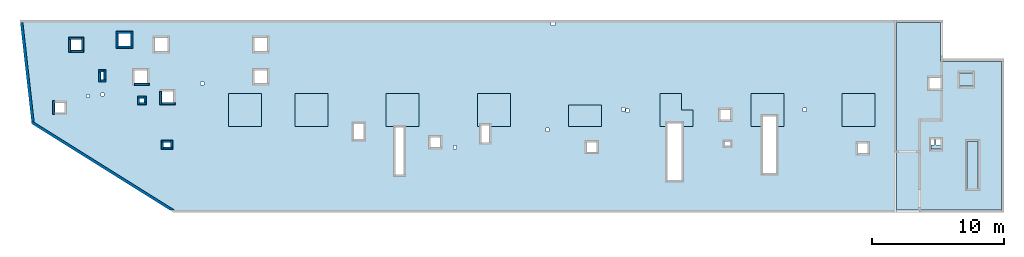
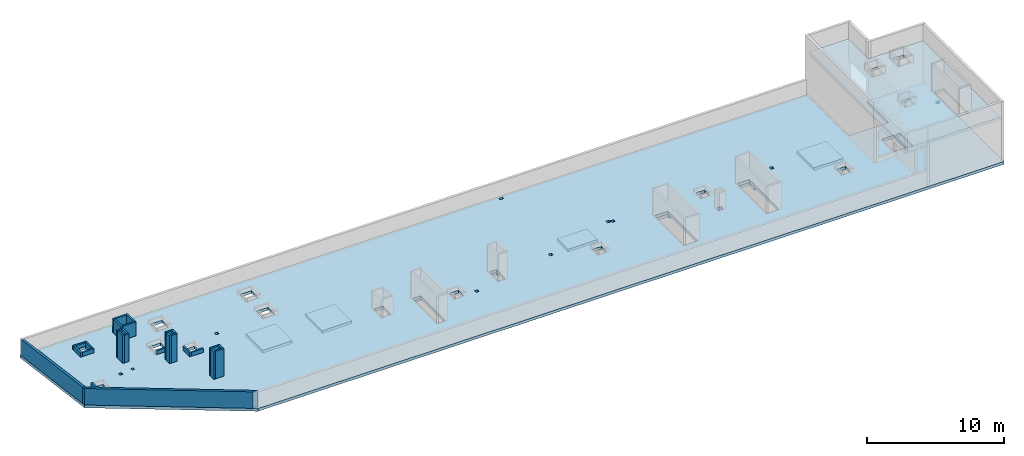
# One storey, part 1 of 3: 26 walls, 10 slabs.
"""IFC4 building model written with IfcOpenShell, lengths in millimetres."""

from ifc_helpers import new_model, entity, si_unit, converted_unit, derived_unit, direction, frame, origin, place, context, subcontext, project, spatial, indexed_curve, outline, extrude, material, type_object, element, save


model = new_model("IFC4")

# Units and contexts
model_context = context("Model", 3, precision=0.01, world=origin(), true_north=direction((6.12303176911189e-17, 1.0)))
plan_context = context("Plan", 3, precision=0.01, world=origin(), true_north=direction((6.12303176911189e-17, 1.0)))
body_context = subcontext(model_context, "Body", "Model", "MODEL_VIEW")
ifc_project = project(units=[si_unit("LENGTHUNIT", "METRE", prefix="MILLI"), si_unit("AREAUNIT", "SQUARE_METRE"), si_unit("VOLUMEUNIT", "CUBIC_METRE"), converted_unit("PLANEANGLEUNIT", "DEGREE", entity("IfcRatioMeasure", 0.0174532925199433), si_unit("PLANEANGLEUNIT", "RADIAN"), dimensions=[0, 0, 0, 0, 0, 0, 0]), si_unit("MASSUNIT", "GRAM", prefix="KILO"), derived_unit("MASSDENSITYUNIT", [(si_unit("MASSUNIT", "GRAM", prefix="KILO"), 1), (si_unit("LENGTHUNIT", "METRE"), -3)]), derived_unit("MOMENTOFINERTIAUNIT", [(si_unit("LENGTHUNIT", "METRE"), 4)]), si_unit("TIMEUNIT", "SECOND"), si_unit("FREQUENCYUNIT", "HERTZ"), si_unit("THERMODYNAMICTEMPERATUREUNIT", "DEGREE_CELSIUS"), derived_unit("THERMALTRANSMITTANCEUNIT", [(si_unit("MASSUNIT", "GRAM", prefix="KILO"), 1), (si_unit("THERMODYNAMICTEMPERATUREUNIT", "KELVIN"), -1), (si_unit("TIMEUNIT", "SECOND"), -3)]), derived_unit("VOLUMETRICFLOWRATEUNIT", [(si_unit("LENGTHUNIT", "METRE"), 3), (si_unit("TIMEUNIT", "SECOND"), -1)]), derived_unit("MASSFLOWRATEUNIT", [(si_unit("MASSUNIT", "GRAM", prefix="KILO"), 1), (si_unit("TIMEUNIT", "SECOND"), -1)]), derived_unit("ROTATIONALFREQUENCYUNIT", [(si_unit("TIMEUNIT", "SECOND"), -1)]), si_unit("ELECTRICCURRENTUNIT", "AMPERE"), si_unit("ELECTRICVOLTAGEUNIT", "VOLT"), si_unit("POWERUNIT", "WATT"), si_unit("FORCEUNIT", "NEWTON", prefix="KILO"), si_unit("ILLUMINANCEUNIT", "LUX"), si_unit("LUMINOUSFLUXUNIT", "LUMEN"), si_unit("LUMINOUSINTENSITYUNIT", "CANDELA"), derived_unit("USERDEFINED", [(si_unit("MASSUNIT", "GRAM", prefix="KILO"), -1), (si_unit("LENGTHUNIT", "METRE"), -2), (si_unit("TIMEUNIT", "SECOND"), 3), (si_unit("LUMINOUSFLUXUNIT", "LUMEN"), 1)]), derived_unit("LINEARVELOCITYUNIT", [(si_unit("LENGTHUNIT", "METRE"), 1), (si_unit("TIMEUNIT", "SECOND"), -1)]), si_unit("PRESSUREUNIT", "PASCAL"), derived_unit("USERDEFINED", [(si_unit("LENGTHUNIT", "METRE"), -2), (si_unit("MASSUNIT", "GRAM", prefix="KILO"), 1), (si_unit("TIMEUNIT", "SECOND"), -2)]), derived_unit("LINEARFORCEUNIT", [(si_unit("MASSUNIT", "GRAM", prefix="KILO"), 1), (si_unit("LENGTHUNIT", "METRE"), 1), (si_unit("TIMEUNIT", "SECOND"), -2), (si_unit("LENGTHUNIT", "METRE"), -1)]), derived_unit("PLANARFORCEUNIT", [(si_unit("MASSUNIT", "GRAM", prefix="KILO"), 1), (si_unit("LENGTHUNIT", "METRE"), 1), (si_unit("TIMEUNIT", "SECOND"), -2), (si_unit("LENGTHUNIT", "METRE"), -2)])], contexts=[model_context, plan_context])

# Site, building, storey
site_placement = place(None, origin())
site = spatial("IfcSite", under=ifc_project, at=site_placement, CompositionType="ELEMENT")
building_placement = place(site_placement, origin())
building = spatial("IfcBuilding", under=site, at=building_placement, CompositionType="ELEMENT")
storey_placement = place(building_placement, frame((0.0, 0.0, 32250.0)))
storey = spatial("IfcBuildingStorey", under=building, at=storey_placement, CompositionType="ELEMENT", Elevation=32250.0)

# Slabs
ifc_material = material()
slab_type_1 = type_object("IfcSlabType", PredefinedType="FLOOR", material=ifc_material)
slab_1_placement = place(storey_placement, origin())
element("IfcSlab", 1, at=slab_1_placement, inside=storey, type_object=slab_type_1, material=ifc_material, PredefinedType="FLOOR", context=body_context, shape_type="SweptSolid", body=[
    extrude(outline(indexed_curve([(-28210.243401448, -11264.7051743326), (34622.2927188456, -11264.7051743326), (34622.2927188456, 375.294825667434), (29822.2935367167, 375.294825667426), (29822.2935367167, -2764.70517433255), (26482.2935367167, -2764.70517433256), (26482.2935367167, 3305.29546503463), (-39839.7064632833, 3305.29546503461), (-38947.8468191642, -4555.23683038923), (-28210.243401448, -11264.7051743326)], self_intersect=False), holes=[indexed_curve([(-36462.7064632833, -2944.70517433183), (-36462.7064632833, -3694.70517433183), (-37212.7064632833, -3694.70517433183), (-37212.7064632833, -2944.70517433183), (-36462.7064632833, -2944.70517433183)], self_intersect=False), indexed_curve([(-35152.7064632833, 1855.29482566817), (-35152.7064632833, 1005.29482566817), (-36002.7064632834, 1005.29482566817), (-36002.7064632834, 1855.29482566817), (-35152.7064632833, 1855.29482566817)], self_intersect=False), indexed_curve([(-33497.7064632833, -2234.70517433184), (-33497.7064632833, -2434.70517433184), (-33697.7064632833, -2434.70517433184), (-33697.7064632833, -2234.70517433184), (-33497.7064632833, -2234.70517433184)], self_intersect=False), indexed_curve([(-34567.7064632833, -2324.70517433183), (-34567.7064632833, -2574.70517433183), (-34817.7064632833, -2574.70517433183), (-34817.7064632833, -2324.70517433183), (-34567.7064632833, -2324.70517433183)], self_intersect=False), indexed_curve([(-25922.7064632833, -1369.70517433186), (-25922.7064632833, -1619.70517433186), (-26172.7064632833, -1619.70517433186), (-26172.7064632833, -1369.70517433186), (-25922.7064632833, -1369.70517433186)], self_intersect=False), indexed_curve([(-28247.7064632833, -2094.70517433186), (-28247.7064632833, -2944.70517433186), (-29097.7064632833, -2944.70517433186), (-29097.7064632833, -2094.70517433186), (-28247.7064632833, -2094.70517433186)], self_intersect=False), indexed_curve([(-30447.7064632833, -2604.70517433184), (-30447.7064632833, -2954.70517433184), (-30797.7064632833, -2954.70517433184), (-30797.7064632833, -2604.70517433184), (-30447.7064632833, -2604.70517433184)], self_intersect=False), indexed_curve([(-30197.7064632833, -494.705174331843), (-30197.7064632833, -1494.70517433184), (-31197.7064632833, -1494.70517433185), (-31197.7064632833, -494.705174331847), (-30197.7064632833, -494.705174331843)], self_intersect=False), indexed_curve([(-28647.7064632833, 1955.29546503462), (-28647.7064632833, 955.295465034616), (-29647.7064632833, 955.295465034613), (-29647.7064632833, 1955.29546503462), (-28647.7064632833, 1955.29546503462)], self_intersect=False), indexed_curve([(-31447.7064632833, 2285.29546503462), (-31447.7064632833, 1325.29546503462), (-32407.7064632833, 1325.29546503462), (-32407.7064632833, 2285.29546503461), (-31447.7064632833, 2285.29546503462)], self_intersect=False), indexed_curve([(-33497.7064632833, -624.705174331836), (-33497.7064632833, -1224.70517433184), (-33747.7064632833, -1224.70517433184), (-33747.7064632833, -624.705174331837), (-33497.7064632833, -624.705174331836)], self_intersect=False), indexed_curve([(-28447.7064632833, -5959.70517433185), (-28447.7064632833, -6309.70517433185), (-28997.7064632833, -6309.70517433185), (-28997.7064632833, -5959.70517433185), (-28447.7064632833, -5959.70517433185)], self_intersect=False), indexed_curve([(-21127.7064632833, -494.704534965379), (-21127.7064632833, -1494.70453496538), (-22127.7064632833, -1494.70453496538), (-22127.7064632833, -494.704534965383), (-21127.7064632833, -494.704534965379)], self_intersect=False), indexed_curve([(-21127.7064632833, 1955.29546503462), (-21127.7064632833, 955.29546503462), (-22127.7064632833, 955.295465034621), (-22127.7064632833, 1955.29546503462), (-21127.7064632833, 1955.29546503462)], self_intersect=False), indexed_curve([(-13822.7064632833, -4554.7051743319), (-13822.7064632833, -5704.7051743319), (-14572.7064632833, -5704.7051743319), (-14572.7064632833, -4554.7051743319), (-13822.7064632833, -4554.7051743319)], self_intersect=False), indexed_curve([(-10782.7064632833, -4794.70517433239), (-10782.7064632833, -8394.7051743324), (-11432.7064632833, -8394.7051743324), (-11432.7064632833, -4794.7051743324), (-10782.7064632833, -4794.70517433239)], self_intersect=False), indexed_curve([(-8037.70646328332, -5559.70517433193), (-8037.70646328333, -6309.70517433194), (-8787.70646328334, -6309.70517433194), (-8787.70646328332, -5559.70517433194), (-8037.70646328332, -5559.70517433193)], self_intersect=False), indexed_curve([(-6797.70646328332, -6189.70517433193), (-6797.70646328332, -6439.70517433193), (-7047.70646328332, -6439.70517433192), (-7047.70646328333, -6189.70517433192), (-6797.70646328332, -6189.70517433193)], self_intersect=False), indexed_curve([(-4327.70646328331, -4664.70517433239), (-4327.7064632833, -5964.70517433239), (-4927.7064632833, -5964.7051743324), (-4927.70646328331, -4664.70517433239), (-4327.70646328331, -4664.70517433239)], self_intersect=False), indexed_curve([(197.293536716675, -4869.70517433194), (197.293536716676, -5119.70517433194), (-52.7064632833368, -5119.70517433194), (-52.706463283329, -4869.70517433194), (197.293536716675, -4869.70517433194)], self_intersect=False), indexed_curve([(652.293536716691, 3105.29546503454), (652.293536716692, 2905.29546503454), (352.293536716691, 2905.29546503454), (352.293536716682, 3105.29546503453), (652.293536716691, 3105.29546503454)], self_intersect=False), indexed_curve([(10222.2935367167, -4504.70517433248), (10222.2935367167, -8804.70517433249), (9122.29353671668, -8804.7051743325), (9122.29353671668, -4504.70517433249), (10222.2935367167, -4504.70517433248)], self_intersect=False), indexed_curve([(5937.29353671669, -3329.70517433197), (5937.29353671669, -3579.70517433197), (5687.29353671668, -3579.70517433197), (5687.29353671669, -3329.70517433197), (5937.29353671669, -3329.70517433197)], self_intersect=False), indexed_curve([(6257.2935367167, -3439.70517433198), (6257.29353671668, -3689.70517433198), (6007.29353671668, -3689.70517433198), (6007.29353671669, -3439.70517433198), (6257.2935367167, -3439.70517433198)], self_intersect=False), indexed_curve([(3812.2935367167, -5934.70517433198), (3812.2935367167, -6684.70517433198), (3062.29353671669, -6684.70517433198), (3062.29353671669, -5934.70517433198), (3812.2935367167, -5934.70517433198)], self_intersect=False), indexed_curve([(13912.2935367167, -3494.705174332), (13912.2935367167, -4244.705174332), (13162.2935367167, -4244.705174332), (13162.2935367167, -3494.705174332), (13912.2935367167, -3494.705174332)], self_intersect=False), indexed_curve([(13902.2935367167, -5919.70517433199), (13902.2935367167, -6219.705174332), (13502.2935367167, -6219.705174332), (13502.2935367167, -5919.70517433199), (13902.2935367167, -5919.70517433199)], self_intersect=False), indexed_curve([(17372.2935367167, -3984.70517433251), (17372.2935367167, -8284.70517433251), (16372.2935367167, -8284.70517433252), (16372.2935367167, -3984.70517433252), (17372.2935367167, -3984.70517433251)], self_intersect=False), indexed_curve([(19662.2935367167, -3369.70517433203), (19662.2935367167, -3619.70517433203), (19412.2935367167, -3619.70517433203), (19412.2935367167, -3369.70517433202), (19662.2935367167, -3369.70517433203)], self_intersect=False), indexed_curve([(24297.2935367167, -6034.70517433203), (24297.2935367167, -6784.70517433204), (23547.2935367167, -6784.70517433205), (23547.2935367167, -6034.70517433203), (24297.2935367167, -6034.70517433203)], self_intersect=False), indexed_curve([(34322.2927188456, -2204.70517433205), (34322.2927188456, -2454.70517433206), (34072.2927188456, -2454.70517433207), (34072.2927188456, -2204.70517433205), (34322.2927188456, -2204.70517433205)], self_intersect=False), indexed_curve([(29372.2935367167, -4364.70517433255), (29372.2935367168, -6169.70517433255), (28332.2935367167, -6169.70517433255), (28332.2935367167, -4364.70517433256), (29372.2935367167, -4364.70517433255)], self_intersect=False), indexed_curve([(29872.2935367167, -4364.70517433255), (29872.2935367167, -6169.70517433255), (29492.2935367167, -6169.70517433255), (29492.2935367167, -4364.70517433255), (29822.2935367167, -4364.70517433255), (29872.2935367167, -4364.70517433255)], self_intersect=False)]), frame((38947.706731838, 17194.7044006881, -250.0)), (0.0, 0.0, 1.0), 249.999999999999),
])
slab_type_2 = type_object("IfcSlabType", PredefinedType="FLOOR", material=ifc_material)
slab_2_placement = place(storey_placement, origin())
element("IfcSlab", 2, at=slab_2_placement, inside=storey, type_object=slab_type_2, material=ifc_material, PredefinedType="FLOOR", context=body_context, shape_type="SweptSolid", body=[
    extrude(outline(indexed_curve([(-1250.0, -1250.0), (1250.0, -1250.0), (1250.0, 1250.0), (-1250.0, 1250.0), (-1250.0, -1250.0)], self_intersect=False)), frame((21170.0002685547, 13699.9992263558, -250.0), z_axis=(0.0, 0.0, -1.0), x_axis=(0.0, 1.0, 0.0)), (0.0, 0.0, 1.0), 249.999999999999),
])
slab_type_3 = type_object("IfcSlabType", PredefinedType="FLOOR", material=ifc_material)
slab_3_placement = place(storey_placement, origin())
element("IfcSlab", 3, at=slab_3_placement, inside=storey, type_object=slab_type_3, material=ifc_material, PredefinedType="FLOOR", context=body_context, shape_type="SweptSolid", body=[
    extrude(outline(indexed_curve([(-1250.0, -1250.0), (1250.0, -1250.0), (1250.0, 1250.0), (-1250.0, 1250.0), (-1250.0, -1250.0)], self_intersect=False)), frame((16150.0002685547, 13699.9992263558, -250.0), z_axis=(0.0, 0.0, -1.0), x_axis=(0.0, 1.0, 0.0)), (0.0, 0.0, 1.0), 249.999999999999),
])
slab_type_4 = type_object("IfcSlabType", PredefinedType="FLOOR", material=ifc_material)
slab_4_placement = place(storey_placement, origin())
element("IfcSlab", 4, at=slab_4_placement, inside=storey, type_object=slab_type_4, material=ifc_material, PredefinedType="FLOOR", context=body_context, shape_type="SweptSolid", body=[
    extrude(outline(indexed_curve([(-1250.0, -1250.0), (1250.0, -1250.0), (1250.0, 1250.0), (-1250.0, 1250.0), (-1250.0, -1250.0)], self_intersect=False)), frame((28070.0002685547, 13699.9992263558, -250.0), z_axis=(0.0, 0.0, -1.0), x_axis=(0.0, 1.0, 0.0)), (0.0, 0.0, 1.0), 249.999999999999),
])
slab_type_5 = type_object("IfcSlabType", PredefinedType="FLOOR", material=ifc_material)
slab_5_placement = place(storey_placement, origin())
element("IfcSlab", 5, at=slab_5_placement, inside=storey, type_object=slab_type_5, material=ifc_material, PredefinedType="FLOOR", context=body_context, shape_type="SweptSolid", body=[
    extrude(outline(indexed_curve([(-645.000000000002, -925.0), (1855.0, -925.0), (1855.0, 1575.0), (-645.000000000002, 1575.0), (-645.000000000001, -24.9999999999964), (-564.999999999999, -24.9999999999967), (-565.000000000001, -624.999999999999), (-645.000000000001, -624.999999999999), (-645.000000000002, -925.0)], self_intersect=False)), frame((34645.0002685547, 13094.9992263558, -250.0), z_axis=(0.0, 0.0, -1.0), x_axis=(0.0, 1.0, 0.0)), (0.0, 0.0, 1.0), 249.999999999999),
])
slab_type_6 = type_object("IfcSlabType", PredefinedType="FLOOR", material=ifc_material)
slab_6_placement = place(storey_placement, origin())
element("IfcSlab", 6, at=slab_6_placement, inside=storey, type_object=slab_type_6, material=ifc_material, PredefinedType="FLOOR", context=body_context, shape_type="SweptSolid", body=[
    extrude(outline(indexed_curve([(-799.999999999968, -1250.0), (799.999999999963, -1250.0), (799.999999999968, 1250.00000000001), (-799.999999999963, 1250.00000000001), (-799.999999999968, -1250.0)], self_intersect=False)), frame((41870.0002685547, 13249.9992263557, -250.0), z_axis=(0.0, 0.0, -1.0), x_axis=(0.0, 1.0, 0.0)), (0.0, 0.0, 1.0), 249.999999999999),
])
slab_type_7 = type_object("IfcSlabType", PredefinedType="FLOOR", material=ifc_material)
slab_7_placement = place(storey_placement, origin())
element("IfcSlab", 7, at=slab_7_placement, inside=storey, type_object=slab_type_7, material=ifc_material, PredefinedType="FLOOR", context=body_context, shape_type="SweptSolid", body=[
    extrude(outline(indexed_curve([(-797.999999999962, -1270.00000000001), (1702.00000000004, -1270.00000000001), (1702.00000000004, 379.999999999997), (451.999999999941, 380.000000000006), (451.999999999945, 1229.99999999999), (-797.999999999953, 1229.99999999999), (-797.999999999957, 379.999999999997), (-558.000000000055, 379.999999999995), (-558.000000000062, -719.999999999997), (-797.99999999996, -719.999999999995), (-797.999999999962, -1270.00000000001)], self_intersect=False)), frame((48790.0002685547, 13247.9992263557, -250.0), z_axis=(0.0, 0.0, -1.0), x_axis=(0.0, 1.0, 0.0)), (0.0, 0.0, 1.0), 249.999999999999),
])
slab_type_8 = type_object("IfcSlabType", PredefinedType="FLOOR", material=ifc_material)
slab_8_placement = place(storey_placement, origin())
element("IfcSlab", 8, at=slab_8_placement, inside=storey, type_object=slab_type_8, material=ifc_material, PredefinedType="FLOOR", context=body_context, shape_type="SweptSolid", body=[
    extrude(outline(indexed_curve([(-814.999999999971, -1325.0), (1685.00000000003, -1325.0), (1685.00000000004, 1175.0), (-814.999999999962, 1175.00000000001), (-814.999999999965, 575.000000000005), (-55.0000000000918, 575.0), (-55.0000000000987, -424.999999999998), (-814.999999999967, -424.999999999993), (-814.999999999971, -1325.0)], self_intersect=False)), frame((55745.0002685547, 13264.9992263557, -250.0), z_axis=(0.0, 0.0, -1.0), x_axis=(0.0, 1.0, 0.0)), (0.0, 0.0, 1.0), 249.999999999999),
])
slab_type_9 = type_object("IfcSlabType", PredefinedType="FLOOR", material=ifc_material)
slab_9_placement = place(storey_placement, origin())
element("IfcSlab", 9, at=slab_9_placement, inside=storey, type_object=slab_type_9, material=ifc_material, PredefinedType="FLOOR", context=body_context, shape_type="SweptSolid", body=[
    extrude(outline(indexed_curve([(-1250.0, -1250.00000000001), (1250.0, -1250.00000000001), (1250.0, 1250.0), (-1250.0, 1250.0), (-1250.0, -1250.00000000001)], self_intersect=False)), frame((62570.0002685547, 13699.9992263557, -250.0), z_axis=(0.0, 0.0, -1.0), x_axis=(0.0, 1.0, 0.0)), (0.0, 0.0, 1.0), 249.999999999999),
])
slab_type_10 = type_object("IfcSlabType", PredefinedType="FLOOR", material=ifc_material)
slab_10_placement = place(storey_placement, origin())
element("IfcSlab", 10, at=slab_10_placement, inside=storey, type_object=slab_type_10, material=ifc_material, PredefinedType="FLOOR", context=body_context, shape_type="SweptSolid", body=[
    extrude(outline(indexed_curve([(-4717.14227294921, 3352.14285714262), (-4717.14227294921, -7887.85714285738), (3222.85690917966, -7887.85714285738), (3222.85690917966, -3492.85714285684), (3222.85690917966, 6282.14285714318), (-117.143090820333, 6282.14285714317), (-117.143090820325, 3352.14285714262), (-4717.14227294921, 3352.14285714262)], self_intersect=False), holes=[indexed_curve([(-117.143090820307, 2122.14285714314), (732.856909179725, 2122.14285714314), (732.856909179725, 1272.14285714314), (-117.143090820307, 1272.14285714314), (-117.143090820307, 2122.14285714314)], self_intersect=False), indexed_curve([(-2567.14309082028, 2482.14285714312), (-1567.14309082028, 2482.14285714312), (-1567.14309082028, 1482.14285714312), (-2567.14309082028, 1482.14285714312), (-2567.14309082028, 2482.14285714312)], self_intersect=False), indexed_curve([(-142.143090820267, -2532.85714285686), (607.856909179736, -2532.85714285686), (607.856909179736, -3282.85714285686), (-142.143090820267, -3282.85714285686), (-142.143090820267, -2532.85714285686)], self_intersect=False), indexed_curve([(-2967.1422729492, -2702.85714285687), (-2117.14227294921, -2702.85714285687), (-2117.14227294921, -6302.85714285688), (-2967.1422729492, -6302.85714285688), (-2967.1422729492, -2702.85714285687)], self_intersect=False)]), frame((68652.8571777344, 14017.8563692128, 3650.0), z_axis=(0.0, 0.0, -1.0), x_axis=(-1.0, 0.0, 0.0)), (0.0, 0.0, -1.0), 249.999999999999),
])

# Walls
wall_type_1 = type_object("IfcWallType", PredefinedType="STANDARD")
wall_1_placement = place(storey_placement, frame((10741.8202757387, 6045.19395197789, 0.0), z_axis=(0.0, 0.0, 1.0), x_axis=(-0.848052743777573, 0.529911826412027, 0.0)))
element("IfcWall", 11, at=wall_1_placement, inside=storey, type_object=wall_type_1, material=ifc_material, PredefinedType="NOTDEFINED", context=body_context, shape_type="SweptSolid", body=[
    extrude(outline(indexed_curve([(12763.0637399361, -100.000000000002), (12604.1325363923, 99.9999999999978), (320.073152365613, 100.000000000001), (-9.89808235374312e-13, -100.000000000001), (12507.6050789753, -100.000000000002), (12763.0637399361, -100.000000000002)], self_intersect=False)), origin(), (0.0, 0.0, 1.0), 1470.0),
])
wall_2_placement = place(storey_placement, frame((88.3401682952891, 12746.6533641364, 0.0), z_axis=(0.0, 0.0, 1.0), x_axis=(-0.11273713659355, 0.993624847733131, 0.0)))
element("IfcWall", 12, at=wall_2_placement, inside=storey, type_object=wall_type_1, material=ifc_material, PredefinedType="NOTDEFINED", context=body_context, shape_type="SweptSolid", body=[
    extrude(outline(indexed_curve([(7590.46314626056, -100.0), (7613.15523912654, 100.0), (158.931203543748, 100.0), (9.11554165483608e-13, -100.0), (7590.46314626056, -100.0)], self_intersect=False)), origin(), (0.0, 0.0, 1.0), 1470.0),
])
wall_type_2 = type_object("IfcWallType", PredefinedType="STANDARD")
wall_3_placement = place(storey_placement, frame((1660.00026855467, 13349.9992263564, 0.0), z_axis=(0.0, 0.0, 1.0), x_axis=(0.0, 1.0, 0.0)))
element("IfcWall", 13, at=wall_3_placement, inside=storey, type_object=wall_type_2, material=ifc_material, PredefinedType="NOTDEFINED", context=body_context, shape_type="SweptSolid", body=[
    extrude(outline(indexed_curve([(1050.0, 74.9999999999999), (-1.08286712929839e-13, 75.0), (1.08286712929839e-13, -75.0), (1050.0, -75.0000000000001), (1050.0, 74.9999999999999)], self_intersect=False)), origin(), (0.0, 0.0, 1.0), 349.999999999998),
])
wall_4_placement = place(storey_placement, frame((2795.00026855467, 19124.9992263564, 0.0)))
element("IfcWall", 14, at=wall_4_placement, inside=storey, type_object=wall_type_2, material=ifc_material, PredefinedType="NOTDEFINED", context=body_context, shape_type="SweptSolid", body=[
    extrude(outline(indexed_curve([(1000.0, 75.0000000000003), (0.0, 75.0000000000003), (0.0, -75.0000000000003), (1000.0, -75.0000000000003), (1000.0, 75.0000000000003)], self_intersect=False)), origin(), (0.0, 0.0, 1.0), 349.999999999998),
])
wall_5_placement = place(storey_placement, frame((2870.00026855467, 18049.9992263564, 0.0), z_axis=(0.0, 0.0, 1.0), x_axis=(0.0, 1.0, 0.0)))
element("IfcWall", 15, at=wall_5_placement, inside=storey, type_object=wall_type_2, material=ifc_material, PredefinedType="NOTDEFINED", context=body_context, shape_type="SweptSolid", body=[
    extrude(outline(indexed_curve([(999.999999999998, 75.0000000000003), (0.0, 75.0000000000003), (0.0, -75.0000000000003), (999.999999999998, -75.0000000000003), (999.999999999998, 75.0000000000003)], self_intersect=False)), origin(), (0.0, 0.0, 1.0), 349.999999999998),
])
wall_6_placement = place(storey_placement, frame((3945.00026855467, 18124.9992263564, 0.0), z_axis=(0.0, 0.0, 1.0), x_axis=(-1.0, 0.0, 0.0)))
element("IfcWall", 16, at=wall_6_placement, inside=storey, type_object=wall_type_2, material=ifc_material, PredefinedType="NOTDEFINED", context=body_context, shape_type="SweptSolid", body=[
    extrude(outline(indexed_curve([(1000.0, 75.0000000000003), (0.0, 75.0000000000003), (0.0, -75.0000000000003), (1000.0, -75.0000000000003), (1000.0, 75.0000000000003)], self_intersect=False)), origin(), (0.0, 0.0, 1.0), 349.999999999998),
])
wall_7_placement = place(storey_placement, frame((3870.00026855467, 19199.9992263564, 0.0), z_axis=(0.0, 0.0, 1.0), x_axis=(0.0, -1.0, 0.0)))
element("IfcWall", 17, at=wall_7_placement, inside=storey, type_object=wall_type_2, material=ifc_material, PredefinedType="NOTDEFINED", context=body_context, shape_type="SweptSolid", body=[
    extrude(outline(indexed_curve([(999.999999999998, 75.0000000000003), (0.0, 75.0000000000003), (0.0, -75.0000000000003), (999.999999999998, -75.0000000000003), (999.999999999998, 75.0000000000003)], self_intersect=False)), origin(), (0.0, 0.0, 1.0), 349.999999999998),
])
wall_8_placement = place(storey_placement, frame((8900.00026855468, 15624.9992263564, 0.0), z_axis=(0.0, 0.0, 1.0), x_axis=(-1.0, 0.0, 0.0)))
element("IfcWall", 18, at=wall_8_placement, inside=storey, type_object=wall_type_2, material=ifc_material, PredefinedType="NOTDEFINED", context=body_context, shape_type="SweptSolid", body=[
    extrude(outline(indexed_curve([(1150.0, 75.0000000000003), (0.0, 75.0000000000003), (0.0, -75.0000000000003), (1150.0, -75.0000000000003), (1150.0, 75.0000000000003)], self_intersect=False)), origin(), (0.0, 0.0, 1.0), 349.999999999998),
])
wall_9_placement = place(storey_placement, frame((9775.00026855468, 14099.9992263564, 0.0), z_axis=(0.0, 0.0, 1.0), x_axis=(0.0, 1.0, 0.0)))
element("IfcWall", 19, at=wall_9_placement, inside=storey, type_object=wall_type_2, material=ifc_material, PredefinedType="NOTDEFINED", context=body_context, shape_type="SweptSolid", body=[
    extrude(outline(indexed_curve([(999.999999999998, 75.0000000000003), (0.0, 75.0000000000003), (0.0, -75.0000000000003), (999.999999999998, -75.0000000000003), (999.999999999998, 75.0000000000003)], self_intersect=False)), origin(), (0.0, 0.0, 1.0), 349.999999999998),
])
wall_10_placement = place(storey_placement, frame((10850.0002685547, 14174.9992263564, 0.0), z_axis=(0.0, 0.0, 1.0), x_axis=(-1.0, 0.0, 0.0)))
element("IfcWall", 20, at=wall_10_placement, inside=storey, type_object=wall_type_2, material=ifc_material, PredefinedType="NOTDEFINED", context=body_context, shape_type="SweptSolid", body=[
    extrude(outline(indexed_curve([(1000.0, 75.0000000000003), (0.0, 75.0000000000003), (0.0, -75.0000000000003), (1000.0, -75.0000000000003), (1000.0, 75.0000000000003)], self_intersect=False)), origin(), (0.0, 0.0, 1.0), 349.999999999998),
])
wall_11_placement = place(storey_placement, frame((8000.00026855468, 14664.9992263564, 0.0)))
element("IfcWall", 21, at=wall_11_placement, inside=storey, type_object=wall_type_2, material=ifc_material, PredefinedType="NOTDEFINED", context=body_context, shape_type="SweptSolid", body=[
    extrude(outline(indexed_curve([(499.999999999999, 75.0000000000003), (0.0, 75.0000000000003), (0.0, -75.0000000000003), (499.999999999999, -75.0000000000003), (499.999999999999, 75.0000000000003)], self_intersect=False)), origin(), (0.0, 0.0, 1.0), 2450.0),
])
for number, where, z_axis, x_axis in (
    (22, (8075.00026855468, 14089.9992263564, 0.0), (0.0, 0.0, 1.0), (0.0, 1.0, 0.0)),
    (23, (8650.00026855468, 14164.9992263564, 0.0), (0.0, 0.0, 1.0), (-1.0, 0.0, 0.0)),
    (24, (8575.00026855468, 14739.9992263564, 0.0), (0.0, 0.0, 1.0), (0.0, -1.0, 0.0)),
):
    element("IfcWall", number, at=place(storey_placement, frame(where, z_axis=z_axis, x_axis=x_axis)), inside=storey, type_object=wall_type_2, material=ifc_material, PredefinedType="NOTDEFINED", context=body_context, shape_type="SweptSolid", body=[
        extrude(outline(indexed_curve([(499.999999999999, 75.0000000000003), (0.0, 75.0000000000003), (0.0, -75.0000000000003), (499.999999999999, -75.0000000000003), (499.999999999999, 75.0000000000003)], self_intersect=False)), origin(), (0.0, 0.0, 1.0), 2450.0),
    ])
wall_12_placement = place(storey_placement, frame((5050.00026855468, 16644.9992263564, 0.0)))
element("IfcWall", 25, at=wall_12_placement, inside=storey, type_object=wall_type_2, material=ifc_material, PredefinedType="NOTDEFINED", context=body_context, shape_type="SweptSolid", body=[
    extrude(outline(indexed_curve([(399.999999999999, 75.0000000000003), (0.0, 75.0000000000003), (0.0, -75.0000000000003), (399.999999999999, -75.0000000000003), (399.999999999999, 75.0000000000003)], self_intersect=False)), origin(), (0.0, 0.0, 1.0), 2450.0),
])
wall_13_placement = place(storey_placement, frame((5125.00026855468, 15819.9992263564, 0.0), z_axis=(0.0, 0.0, 1.0), x_axis=(0.0, 1.0, 0.0)))
element("IfcWall", 26, at=wall_13_placement, inside=storey, type_object=wall_type_2, material=ifc_material, PredefinedType="NOTDEFINED", context=body_context, shape_type="SweptSolid", body=[
    extrude(outline(indexed_curve([(750.000000000003, 75.0000000000003), (0.0, 75.0000000000003), (0.0, -75.0000000000003), (750.000000000003, -75.0000000000003), (750.000000000003, 75.0000000000003)], self_intersect=False)), origin(), (0.0, 0.0, 1.0), 2450.0),
])
wall_14_placement = place(storey_placement, frame((5600.00026855468, 15894.9992263564, 0.0), z_axis=(0.0, 0.0, 1.0), x_axis=(-1.0, 0.0, 0.0)))
element("IfcWall", 27, at=wall_14_placement, inside=storey, type_object=wall_type_2, material=ifc_material, PredefinedType="NOTDEFINED", context=body_context, shape_type="SweptSolid", body=[
    extrude(outline(indexed_curve([(400.000000000003, 75.0000000000003), (0.0, 75.0000000000003), (0.0, -75.0000000000003), (400.000000000003, -75.0000000000003), (400.000000000003, 75.0000000000003)], self_intersect=False)), origin(), (0.0, 0.0, 1.0), 2450.0),
])
wall_15_placement = place(storey_placement, frame((5525.00026855468, 16719.9992263564, 0.0), z_axis=(0.0, 0.0, 1.0), x_axis=(0.0, -1.0, 0.0)))
element("IfcWall", 28, at=wall_15_placement, inside=storey, type_object=wall_type_2, material=ifc_material, PredefinedType="NOTDEFINED", context=body_context, shape_type="SweptSolid", body=[
    extrude(outline(indexed_curve([(750.000000000003, 74.9999999999997), (2.75612141970114e-13, 75.0000000000003), (-2.75612141970114e-13, -75.0000000000003), (750.000000000003, -75.0000000000009), (750.000000000003, 74.9999999999997)], self_intersect=False)), origin(), (0.0, 0.0, 1.0), 2450.0),
])
wall_16_placement = place(storey_placement, frame((6390.00026855468, 19554.9998657229, 0.0)))
element("IfcWall", 29, at=wall_16_placement, inside=storey, type_object=wall_type_2, material=ifc_material, PredefinedType="NOTDEFINED", context=body_context, shape_type="SweptSolid", body=[
    extrude(outline(indexed_curve([(1110.0, 75.0000000000003), (0.0, 75.0000000000003), (0.0, -75.0000000000003), (1110.0, -75.0000000000003), (1110.0, 75.0000000000003)], self_intersect=False)), origin(), (0.0, 0.0, 1.0), 1250.0),
])
for number, where, z_axis, x_axis in (
    (30, (6465.00026855468, 18369.9998657229, 0.0), (0.0, 0.0, 1.0), (0.0, 1.0, 0.0)),
    (31, (7650.00026855469, 18444.9998657229, 0.0), (0.0, 0.0, 1.0), (-1.0, 0.0, 0.0)),
):
    element("IfcWall", number, at=place(storey_placement, frame(where, z_axis=z_axis, x_axis=x_axis)), inside=storey, type_object=wall_type_2, material=ifc_material, PredefinedType="NOTDEFINED", context=body_context, shape_type="SweptSolid", body=[
        extrude(outline(indexed_curve([(1110.0, 75.0000000000003), (0.0, 75.0000000000003), (0.0, -75.0000000000003), (1110.0, -75.0000000000003), (1110.0, 75.0000000000003)], self_intersect=False)), origin(), (0.0, 0.0, 1.0), 1250.0),
    ])
wall_17_placement = place(storey_placement, frame((7575.00026855468, 19629.9998657229, 0.0), z_axis=(0.0, 0.0, 1.0), x_axis=(0.0, -1.0, 0.0)))
element("IfcWall", 32, at=wall_17_placement, inside=storey, type_object=wall_type_2, material=ifc_material, PredefinedType="NOTDEFINED", context=body_context, shape_type="SweptSolid", body=[
    extrude(outline(indexed_curve([(1110.0, 75.0000000000003), (7.31666979255673e-14, 75.0000000000003), (-7.31666979255673e-14, -75.0000000000003), (1110.0, -75.0000000000003), (1110.0, 75.0000000000003)], self_intersect=False)), origin(), (0.0, 0.0, 1.0), 1250.0),
])
wall_18_placement = place(storey_placement, frame((9800.00026855467, 11309.9992263564, 0.0)))
element("IfcWall", 33, at=wall_18_placement, inside=storey, type_object=wall_type_2, material=ifc_material, PredefinedType="NOTDEFINED", context=body_context, shape_type="SweptSolid", body=[
    extrude(outline(indexed_curve([(700.000000000001, 75.0000000000003), (0.0, 75.0000000000003), (0.0, -75.0000000000003), (700.000000000001, -75.0000000000003), (700.000000000001, 75.0000000000003)], self_intersect=False)), origin(), (0.0, 0.0, 1.0), 2450.0),
])
wall_19_placement = place(storey_placement, frame((9875.00026855467, 10734.9992263564, 0.0), z_axis=(0.0, 0.0, 1.0), x_axis=(0.0, 1.0, 0.0)))
element("IfcWall", 34, at=wall_19_placement, inside=storey, type_object=wall_type_2, material=ifc_material, PredefinedType="NOTDEFINED", context=body_context, shape_type="SweptSolid", body=[
    extrude(outline(indexed_curve([(500.000000000001, 75.0000000000003), (0.0, 75.0000000000003), (0.0, -75.0000000000003), (500.000000000001, -75.0000000000003), (500.000000000001, 75.0000000000003)], self_intersect=False)), origin(), (0.0, 0.0, 1.0), 2450.0),
])
wall_20_placement = place(storey_placement, frame((10650.0002685547, 10809.9992263564, 0.0), z_axis=(0.0, 0.0, 1.0), x_axis=(-1.0, 0.0, 0.0)))
element("IfcWall", 35, at=wall_20_placement, inside=storey, type_object=wall_type_2, material=ifc_material, PredefinedType="NOTDEFINED", context=body_context, shape_type="SweptSolid", body=[
    extrude(outline(indexed_curve([(700.000000000001, 75.0000000000003), (0.0, 75.0000000000003), (0.0, -75.0000000000003), (700.000000000001, -75.0000000000003), (700.000000000001, 75.0000000000003)], self_intersect=False)), origin(), (0.0, 0.0, 1.0), 2450.0),
])
wall_21_placement = place(storey_placement, frame((10575.0002685547, 11384.9992263564, 0.0), z_axis=(0.0, 0.0, 1.0), x_axis=(0.0, -1.0, 0.0)))
element("IfcWall", 36, at=wall_21_placement, inside=storey, type_object=wall_type_2, material=ifc_material, PredefinedType="NOTDEFINED", context=body_context, shape_type="SweptSolid", body=[
    extrude(outline(indexed_curve([(500.000000000001, 75.0000000000003), (0.0, 75.0000000000003), (0.0, -75.0000000000003), (500.000000000001, -75.0000000000003), (500.000000000001, 75.0000000000003)], self_intersect=False)), origin(), (0.0, 0.0, 1.0), 2450.0),
])

save(model, "model.ifc")
